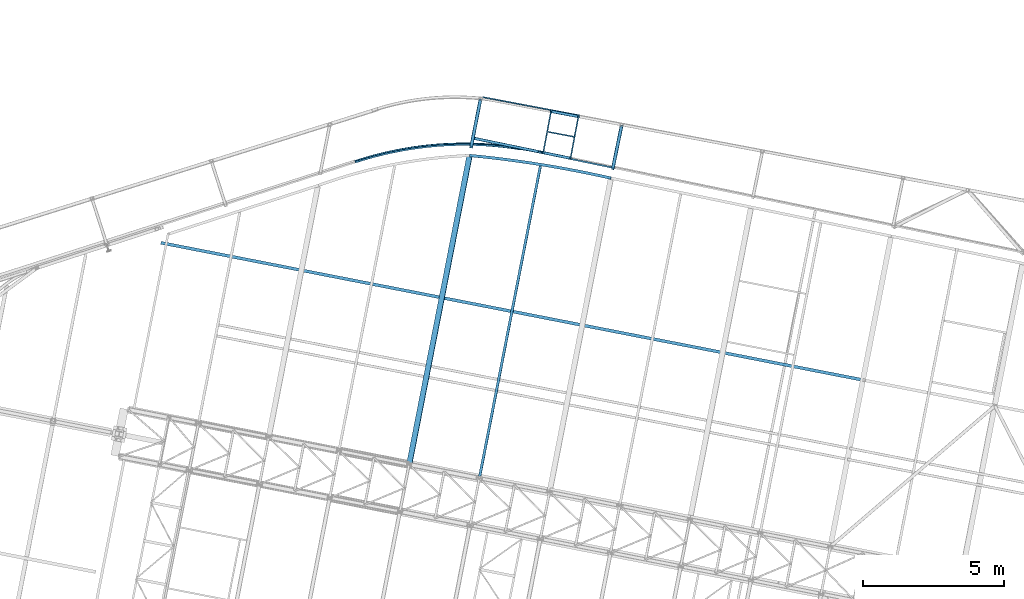
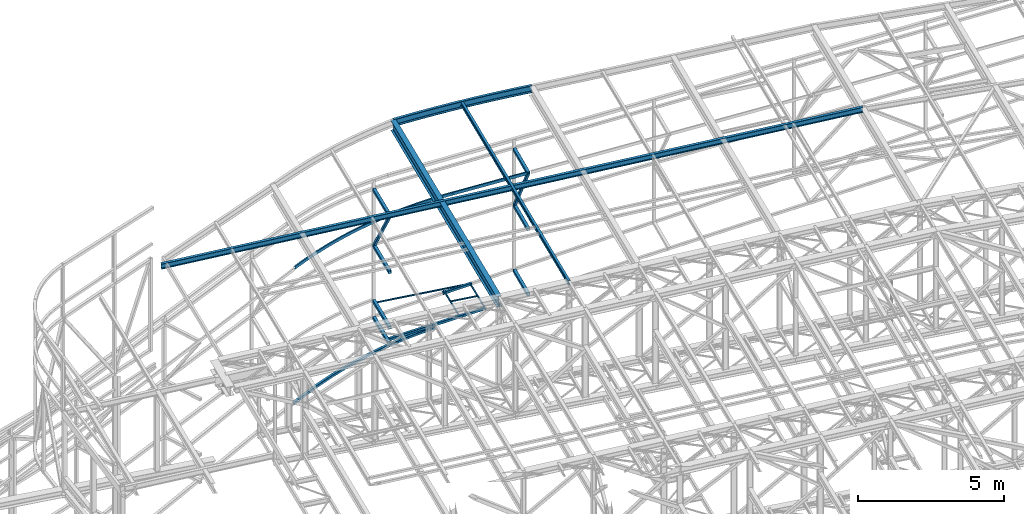
# One storey, part 87 of 215: 21 beams, 2 members, 23 elements without a shape of their own.
"""IFC2X3 building model written with IfcOpenShell, lengths in millimetres."""

from ifc_helpers import new_model, entity, si_unit, frame, origin_with_axes, origin_2d_with_axis, place, context, subcontext, project, spatial, hollow_rectangle, i_section, u_section, extrude, material, type_object, element, aggregate, save


model = new_model("IFC2X3")

# Units and contexts
model_context = context("Model", 3, precision=1e-05, world=origin_with_axes())
body_context = subcontext(model_context, "Body", "Model", "MODEL_VIEW")
ifc_project = project(units=[si_unit("LENGTHUNIT", "METRE", prefix="MILLI"), si_unit("AREAUNIT", "SQUARE_METRE"), si_unit("VOLUMEUNIT", "CUBIC_METRE"), si_unit("MASSUNIT", "GRAM", prefix="KILO"), si_unit("TIMEUNIT", "SECOND"), si_unit("PLANEANGLEUNIT", "RADIAN"), si_unit("SOLIDANGLEUNIT", "STERADIAN"), si_unit("THERMODYNAMICTEMPERATUREUNIT", "DEGREE_CELSIUS"), si_unit("LUMINOUSINTENSITYUNIT", "LUMEN")], contexts=[model_context])

# Site, building, storey
site_placement = place(None, origin_with_axes())
site = spatial("IfcSite", under=ifc_project, at=site_placement, CompositionType="ELEMENT")
building_placement = place(site_placement, origin_with_axes())
building = spatial("IfcBuilding", under=site, at=building_placement, Name="Undefined", CompositionType="ELEMENT")
storey_placement = place(building_placement, origin_with_axes())
storey = spatial("IfcBuildingStorey", under=building, at=storey_placement, Name="Undefined", CompositionType="ELEMENT", Elevation=0.0)

# Assembly, beam
assembly_1_placement = place(storey_placement, origin_with_axes())
assembly_1 = element("IfcElementAssembly", 1, at=assembly_1_placement, inside=storey, Name="Steel Assembly", AssemblyPlace="NOTDEFINED", PredefinedType="RIGID_FRAME")
ifc_material = material(Name="STEEL/S275JR")
beam_type_1 = type_object("IfcBeamType", PredefinedType="NOTDEFINED")
beam_1_placement = place(assembly_1_placement, frame((60846.3040678389, 64492.0568831528, 2809.17321889622), z_axis=(-0.981422412140383, 0.191859451027444, 0.0), x_axis=(-0.191859508000518, -0.981422401002646, -1.00000033853845e-09)))
beam_1 = element("IfcBeam", 2, at=beam_1_placement, type_object=beam_type_1, material=ifc_material, context=body_context, shape_type="SweptSolid", body=[
    extrude(hollow_rectangle(XDim=120.0, YDim=120.0, WallThickness=5.0, InnerFilletRadius=5.0, OuterFilletRadius=10.0, at=origin_2d_with_axis()), frame((1602.56698386637, -4.54747350555061e-13, -3.72828463453371e-31), z_axis=(-1.0, 0.0, 0.0), x_axis=(-6.93889390390723e-18, -1.0, -3.46944695195361e-18)), (0.0, 0.0, 1.0), 1602.6),
])
aggregate(assembly_1, [beam_1])

assembly_2_placement = place(storey_placement, origin_with_axes())
assembly_2 = element("IfcElementAssembly", 3, at=assembly_2_placement, inside=storey, Name="Steel Assembly", AssemblyPlace="NOTDEFINED", PredefinedType="RIGID_FRAME")
beam_2_placement = place(assembly_2_placement, frame((60846.3043026314, 64492.0568371658, 3509.99791160722), z_axis=(-0.981422412140383, 0.191859451027444, 0.0), x_axis=(-0.191859508000518, -0.981422401002646, -1.00000033853845e-09)))
beam_2 = element("IfcBeam", 4, at=beam_2_placement, type_object=beam_type_1, material=ifc_material, context=body_context, shape_type="SweptSolid", body=[
    extrude(hollow_rectangle(XDim=120.0, YDim=120.0, WallThickness=5.0, InnerFilletRadius=5.0, OuterFilletRadius=10.0, at=origin_2d_with_axis()), frame((1692.56697598015, -4.54747350886464e-13, -4.69781706863335e-14), z_axis=(-1.0, 0.0, 0.0), x_axis=(-6.93889390390723e-18, -1.0, -3.46944695195361e-18)), (0.0, 0.0, 1.0), 1692.6),
])
aggregate(assembly_2, [beam_2])

assembly_3_placement = place(storey_placement, origin_with_axes())
assembly_3 = element("IfcElementAssembly", 5, at=assembly_3_placement, inside=storey, Name="Steel Assembly", AssemblyPlace="NOTDEFINED", PredefinedType="RIGID_FRAME")
beam_3_placement = place(assembly_3_placement, frame((60846.3043026202, 64492.0568372251, 5833.71199781246), z_axis=(-0.981422412140383, 0.191859451027444, 0.0), x_axis=(-0.191859508000518, -0.981422401002646, -1.00000033853845e-09)))
beam_3 = element("IfcBeam", 6, at=beam_3_placement, type_object=beam_type_1, material=ifc_material, context=body_context, shape_type="SweptSolid", body=[
    extrude(hollow_rectangle(XDim=120.0, YDim=120.0, WallThickness=5.0, InnerFilletRadius=5.0, OuterFilletRadius=10.0, at=origin_2d_with_axis()), frame((1692.56697598015, -4.54747350886464e-13, -4.69781706863335e-14), z_axis=(-1.0, 0.0, 0.0), x_axis=(-6.93889390390723e-18, -1.0, -3.46944695195361e-18)), (0.0, 0.0, 1.0), 1692.6),
])
aggregate(assembly_3, [beam_3])

assembly_4_placement = place(storey_placement, origin_with_axes())
assembly_4 = element("IfcElementAssembly", 7, at=assembly_4_placement, inside=storey, Name="Steel Assembly", AssemblyPlace="NOTDEFINED", PredefinedType="RIGID_FRAME")
beam_4_placement = place(assembly_4_placement, frame((60846.3043044082, 64492.0568372218, 8175.38817858846), z_axis=(-0.981422412140383, 0.191859451027444, 0.0), x_axis=(-0.191859508000518, -0.981422401002646, -1.00000033853845e-09)))
beam_4 = element("IfcBeam", 8, at=beam_4_placement, type_object=beam_type_1, material=ifc_material, context=body_context, shape_type="SweptSolid", body=[
    extrude(hollow_rectangle(XDim=120.0, YDim=120.0, WallThickness=5.0, InnerFilletRadius=5.0, OuterFilletRadius=10.0, at=origin_2d_with_axis()), frame((1692.56697598015, -4.54747350886464e-13, -4.69781706863335e-14), z_axis=(-1.0, 0.0, 0.0), x_axis=(-6.93889390390723e-18, -1.0, -3.46944695195361e-18)), (0.0, 0.0, 1.0), 1692.6),
])
aggregate(assembly_4, [beam_4])

assembly_5_placement = place(storey_placement, origin_with_axes())
assembly_5 = element("IfcElementAssembly", 9, at=assembly_5_placement, inside=storey, Name="Steel Assembly", AssemblyPlace="NOTDEFINED", PredefinedType="RIGID_FRAME")
beam_5_placement = place(assembly_5_placement, frame((65863.2951128637, 63551.7907925705, 6332.98385608144), z_axis=(0.97957922139794, -0.201058571081677, 0.0), x_axis=(-0.201058572041247, -0.979579221200988, -1.00000033874093e-09)))
beam_5 = element("IfcBeam", 10, at=beam_5_placement, type_object=beam_type_1, material=ifc_material, context=body_context, shape_type="SweptSolid", body=[
    extrude(hollow_rectangle(XDim=120.0, YDim=120.0, WallThickness=5.0, InnerFilletRadius=5.0, OuterFilletRadius=10.0, at=origin_2d_with_axis()), frame((1518.08277362937, 9.09494701772928e-13, 4.21352612142536e-14), z_axis=(-1.0, 0.0, 0.0), x_axis=(-6.93889390390723e-18, -1.0, -3.46944695195361e-18)), (0.0, 0.0, 1.0), 1518.1),
])
aggregate(assembly_5, [beam_5])

assembly_6_placement = place(storey_placement, origin_with_axes())
assembly_6 = element("IfcElementAssembly", 11, at=assembly_6_placement, inside=storey, Name="Steel Assembly", AssemblyPlace="NOTDEFINED", PredefinedType="RIGID_FRAME")
beam_6_placement = place(assembly_6_placement, frame((65863.2951130029, 63551.7907946507, 3602.7948409245), z_axis=(0.97957922139794, -0.201058571081677, 0.0), x_axis=(-0.201058572041247, -0.979579221200988, -1.00000033874093e-09)))
beam_6 = element("IfcBeam", 12, at=beam_6_placement, type_object=beam_type_1, material=ifc_material, context=body_context, shape_type="SweptSolid", body=[
    extrude(hollow_rectangle(XDim=120.0, YDim=120.0, WallThickness=5.0, InnerFilletRadius=5.0, OuterFilletRadius=10.0, at=origin_2d_with_axis()), frame((1518.08277362937, 9.09494701772928e-13, 4.21352612142536e-14), z_axis=(-1.0, 0.0, 0.0), x_axis=(-6.93889390390723e-18, -1.0, -3.46944695195361e-18)), (0.0, 0.0, 1.0), 1518.1),
])
aggregate(assembly_6, [beam_6])

assembly_7_placement = place(storey_placement, origin_with_axes())
assembly_7 = element("IfcElementAssembly", 13, at=assembly_7_placement, inside=storey, Name="Steel Assembly", AssemblyPlace="NOTDEFINED", PredefinedType="RIGID_FRAME")
beam_7_placement = place(assembly_7_placement, frame((65863.2951129865, 63551.7907898595, 8674.00008624477), z_axis=(0.97957922139794, -0.201058571081677, 0.0), x_axis=(-0.201058572041247, -0.979579221200988, -1.00000033874093e-09)))
beam_7 = element("IfcBeam", 14, at=beam_7_placement, type_object=beam_type_1, material=ifc_material, context=body_context, shape_type="SweptSolid", body=[
    extrude(hollow_rectangle(XDim=120.0, YDim=120.0, WallThickness=5.0, InnerFilletRadius=5.0, OuterFilletRadius=10.0, at=origin_2d_with_axis()), frame((1518.08277362937, 9.09494701772928e-13, 4.21352612142536e-14), z_axis=(-1.0, 0.0, 0.0), x_axis=(-6.93889390390723e-18, -1.0, -3.46944695195361e-18)), (0.0, 0.0, 1.0), 1518.1),
])
aggregate(assembly_7, [beam_7])

assembly_8_placement = place(storey_placement, origin_with_axes())
assembly_8 = element("IfcElementAssembly", 15, at=assembly_8_placement, inside=storey, Name="Steel Assembly", AssemblyPlace="NOTDEFINED", PredefinedType="RIGID_FRAME")
beam_type_2 = type_object("IfcBeamType", PredefinedType="NOTDEFINED")
beam_8_placement = place(assembly_8_placement, frame((56400.4261079201, 62309.4328289021, 2102.02367266955), z_axis=(-0.0819909300056613, 0.996340556068799, 0.024145056001667), x_axis=(0.986497951902203, 0.077687055992299, 0.144175282985707)))
beam_8 = element("IfcBeam", 16, at=beam_8_placement, type_object=beam_type_2, material=ifc_material, Name="LISSE", context=body_context, shape_type="SweptSolid", body=[
    entity("IfcRevolvedAreaSolid", entity("IfcRectangleHollowProfileDef", "AREA", None, entity("IfcAxis2Placement2D", entity("IfcCartesianPoint", [0.0, 0.0]), entity("IfcDirection", [1.0, 0.0])), 100.0, 100.0, 5.0, 5.0, 10.0), entity("IfcAxis2Placement3D", entity("IfcCartesianPoint", [5938.35393194914, 1.64822431590581e-13, -3.86302574040425e-14]), entity("IfcDirection", [-0.971610112147189, -2.77884267791936e-17, 0.23658780605375]), entity("IfcDirection", [-6.93889390390723e-18, -1.0, -3.46944695195361e-18])), entity("IfcAxis1Placement", entity("IfcCartesianPoint", [0.0, -12550.0, 0.0]), entity("IfcDirection", [1.0, 0.0, 0.0])), 0.477704889269038),
])
aggregate(assembly_8, [beam_8])

assembly_9_placement = place(storey_placement, origin_with_axes())
assembly_9 = element("IfcElementAssembly", 17, at=assembly_9_placement, inside=storey, Name="Steel Assembly", AssemblyPlace="NOTDEFINED", PredefinedType="RIGID_FRAME")
beam_9_placement = place(assembly_9_placement, frame((63035.3702725266, 62638.7162082398, 3180.57821487935), z_axis=(0.202811574087882, 0.979217782424315, -5.19999998912453e-08), x_axis=(0.967507450041113, -0.200386169008516, 0.154190523006552)))
beam_9 = element("IfcBeam", 18, at=beam_9_placement, type_object=beam_type_2, material=ifc_material, Name="LISSE", context=body_context, shape_type="SweptSolid", body=[
    extrude(hollow_rectangle(XDim=100.0, YDim=100.0, WallThickness=5.0, InnerFilletRadius=5.0, OuterFilletRadius=10.0, at=origin_2d_with_axis()), frame((1064.70209946629, -9.09494701772928e-13, -1.45202017760121e-11), z_axis=(-1.0, 0.0, 0.0), x_axis=(-6.93889390390723e-18, -1.0, -3.46944695195361e-18)), (0.0, 0.0, 1.0), 1064.7),
])
aggregate(assembly_9, [beam_9])

assembly_10_placement = place(storey_placement, origin_with_axes())
assembly_10 = element("IfcElementAssembly", 19, at=assembly_10_placement, inside=storey, Name="Steel Assembly", AssemblyPlace="NOTDEFINED", PredefinedType="RIGID_FRAME")
beam_10_placement = place(assembly_10_placement, frame((60564.7939410119, 63150.4118311355, 2786.84537497598), z_axis=(0.202811574087882, 0.979217782424315, -5.19999998912453e-08), x_axis=(0.967507450041113, -0.200386169008516, 0.154190523006552)))
beam_10 = element("IfcBeam", 20, at=beam_10_placement, type_object=beam_type_2, material=ifc_material, Name="LISSE", context=body_context, shape_type="SweptSolid", body=[
    extrude(hollow_rectangle(XDim=100.0, YDim=100.0, WallThickness=5.0, InnerFilletRadius=5.0, OuterFilletRadius=10.0, at=origin_2d_with_axis()), frame((2553.54760472388, 9.8036988540395e-13, 6.11927324869339e-14), z_axis=(-1.0, 0.0, 0.0), x_axis=(-6.93889390390723e-18, -1.0, -3.46944695195361e-18)), (0.0, 0.0, 1.0), 2553.5),
])
aggregate(assembly_10, [beam_10])

assembly_11_placement = place(storey_placement, origin_with_axes())
assembly_11 = element("IfcElementAssembly", 21, at=assembly_11_placement, inside=storey, Name="Steel Assembly", AssemblyPlace="NOTDEFINED", PredefinedType="RIGID_FRAME")
beam_11_placement = place(assembly_11_placement, frame((63332.9613900655, 64100.4917012047, 3201.85182154818), z_axis=(0.185059002917875, 0.982727411563879, 0.0), x_axis=(0.970975106212946, -0.182845907040102, 0.154190523033816)))
beam_11 = element("IfcBeam", 22, at=beam_11_placement, type_object=beam_type_2, material=ifc_material, Name="LISSE", context=body_context, shape_type="SweptSolid", body=[
    extrude(hollow_rectangle(XDim=100.0, YDim=100.0, WallThickness=5.0, InnerFilletRadius=5.0, OuterFilletRadius=10.0, at=origin_2d_with_axis()), frame((1064.70209946629, -9.09494701772928e-13, -1.45202017760121e-11), z_axis=(-1.0, 0.0, 0.0), x_axis=(-6.93889390390723e-18, -1.0, -3.46944695195361e-18)), (0.0, 0.0, 1.0), 1064.7),
])
aggregate(assembly_11, [beam_11])

assembly_12_placement = place(storey_placement, origin_with_axes())
assembly_12 = element("IfcElementAssembly", 23, at=assembly_12_placement, inside=storey, Name="Steel Assembly", AssemblyPlace="NOTDEFINED", PredefinedType="RIGID_FRAME")
beam_type_3 = type_object("IfcBeamType", PredefinedType="NOTDEFINED")
beam_12_placement = place(assembly_12_placement, frame((63200.6196642151, 63377.4039981066, 3334.99966279131), z_axis=(0.0, 0.0, 1.0), x_axis=(0.982583013200276, -0.185824170037877, 0.0)))
beam_12 = element("IfcBeam", 24, at=beam_12_placement, type_object=beam_type_3, material=ifc_material, context=body_context, shape_type="SweptSolid", body=[
    extrude(hollow_rectangle(XDim=50.0, YDim=50.0, WallThickness=3.0, InnerFilletRadius=3.0, OuterFilletRadius=6.0, at=origin_2d_with_axis()), frame((1040.00001665534, 0.0, 4.54747350886464e-13), z_axis=(-1.0, 0.0, 0.0), x_axis=(-6.93889390390723e-18, -1.0, -3.46944695195361e-18)), (0.0, 0.0, 1.0), 1040.0),
])
aggregate(assembly_12, [beam_12])

assembly_13_placement = place(storey_placement, origin_with_axes())
assembly_13 = element("IfcElementAssembly", 25, at=assembly_13_placement, inside=storey, Name="Steel Assembly", AssemblyPlace="NOTDEFINED", PredefinedType="RIGID_FRAME")
beam_13_placement = place(assembly_13_placement, frame((60929.1456341112, 64603.2398358579, 3334.9996627777), z_axis=(0.0, 0.0, 1.0), x_axis=(0.982565923617697, -0.185914511927664, 0.0)))
beam_13 = element("IfcBeam", 26, at=beam_13_placement, type_object=beam_type_3, material=ifc_material, context=body_context, shape_type="SweptSolid", body=[
    extrude(hollow_rectangle(XDim=50.0, YDim=50.0, WallThickness=3.0, InnerFilletRadius=3.0, OuterFilletRadius=6.0, at=origin_2d_with_axis()), frame((3499.26420533172, 0.0, 0.0), z_axis=(-1.0, 0.0, 0.0), x_axis=(-6.93889390390723e-18, -1.0, -3.46944695195361e-18)), (0.0, 0.0, 1.0), 3499.3),
])
aggregate(assembly_13, [beam_13])

assembly_14_placement = place(storey_placement, origin_with_axes())
assembly_14 = element("IfcElementAssembly", 27, at=assembly_14_placement, inside=storey, Name="Steel Assembly", AssemblyPlace="NOTDEFINED", PredefinedType="RIGID_FRAME")
beam_14_placement = place(assembly_14_placement, frame((64045.0524665882, 62377.9663630105, 3334.99966285638), z_axis=(0.0, 0.0, -1.0), x_axis=(0.185294237017553, 0.982683085093095, 0.0)))
beam_14 = element("IfcBeam", 28, at=beam_14_placement, type_object=beam_type_3, material=ifc_material, context=body_context, shape_type="SweptSolid", body=[
    extrude(hollow_rectangle(XDim=50.0, YDim=50.0, WallThickness=3.0, InnerFilletRadius=3.0, OuterFilletRadius=6.0, at=origin_2d_with_axis()), frame((1632.17012996255, 0.0, 0.0), z_axis=(-1.0, 0.0, 0.0), x_axis=(-6.93889390390723e-18, -1.0, -3.46944695195361e-18)), (0.0, 0.0, 1.0), 1632.2),
])
aggregate(assembly_14, [beam_14])

assembly_15_placement = place(storey_placement, origin_with_axes())
assembly_15 = element("IfcElementAssembly", 29, at=assembly_15_placement, inside=storey, Name="Steel Assembly", AssemblyPlace="NOTDEFINED", PredefinedType="RIGID_FRAME")
beam_15_placement = place(assembly_15_placement, frame((63075.6414931099, 62579.6785148873, 3334.99966267219), z_axis=(0.0, 0.0, 1.0), x_axis=(0.185294237017553, 0.982683085093095, 0.0)))
beam_15 = element("IfcBeam", 30, at=beam_15_placement, type_object=beam_type_3, material=ifc_material, context=body_context, shape_type="SweptSolid", body=[
    extrude(hollow_rectangle(XDim=50.0, YDim=50.0, WallThickness=3.0, InnerFilletRadius=3.0, OuterFilletRadius=6.0, at=origin_2d_with_axis()), frame((1614.13814754926, 0.0, 0.0), z_axis=(-1.0, 0.0, 0.0), x_axis=(-6.93889390390723e-18, -1.0, -3.46944695195361e-18)), (0.0, 0.0, 1.0), 1614.1),
])
aggregate(assembly_15, [beam_15])

assembly_16_placement = place(storey_placement, origin_with_axes())
assembly_16 = element("IfcElementAssembly", 31, at=assembly_16_placement, inside=storey, Name="Steel Assembly", AssemblyPlace="NOTDEFINED", PredefinedType="RIGID_FRAME")
beam_type_4 = type_object("IfcBeamType", Name="IPE180", PredefinedType="NOTDEFINED")
beam_16_placement = place(assembly_16_placement, frame((60813.588311652, 51052.3122572833, 12435.6309830991), z_axis=(-0.0304080349967745, 0.00594450299936818, 0.999519891893966), x_axis=(0.191845211931802, 0.981425195651121, 9.9999994476379e-10)))
beam_16 = element("IfcBeam", 32, at=beam_16_placement, type_object=beam_type_4, material=ifc_material, ObjectType="IPE180", context=body_context, shape_type="SweptSolid", body=[
    extrude(i_section(OverallWidth=91.0, OverallDepth=180.0, WebThickness=5.300000191, FlangeThickness=8.0, FilletRadius=9.0, at=origin_2d_with_axis()), frame((11368.1805399916, -7.29749999652721e-12, 1.69898432619937e-17), z_axis=(-1.0, 0.0, 0.0), x_axis=(-6.93889390390723e-18, -1.0, -3.46944695195361e-18)), (0.0, 0.0, 1.0), 11368.2),
])
aggregate(assembly_16, [beam_16])

# Assembly, member
assembly_17_placement = place(storey_placement, origin_with_axes())
assembly_17 = element("IfcElementAssembly", 33, at=assembly_17_placement, inside=storey, Name="Steel Assembly", AssemblyPlace="NOTDEFINED", PredefinedType="RIGID_FRAME")
member_type = type_object("IfcMemberType", PredefinedType="NOTDEFINED")
member_1_placement = place(assembly_17_placement, frame((60521.5693642332, 62830.9337504331, 8195.38817689351), z_axis=(-0.981422153904125, 0.191860771981257, 9.71999999724718e-07), x_axis=(0.111763166992201, 0.571704353960101, -0.812811863943273)))
member_1 = element("IfcMember", 34, at=member_1_placement, type_object=member_type, material=ifc_material, context=body_context, shape_type="SweptSolid", body=[
    extrude(hollow_rectangle(XDim=100.0, YDim=100.0, WallThickness=5.0, InnerFilletRadius=5.0, OuterFilletRadius=10.0, at=origin_2d_with_axis()), frame((2905.56312381349, -7.27595761418343e-12, 7.23360164309341e-12), z_axis=(-1.0, 0.0, 0.0), x_axis=(-6.93889390390723e-18, -1.0, -3.46944695195361e-18)), (0.0, 0.0, 1.0), 2905.6),
])
aggregate(assembly_17, [member_1])

assembly_18_placement = place(storey_placement, origin_with_axes())
assembly_18 = element("IfcElementAssembly", 35, at=assembly_18_placement, inside=storey, Name="Steel Assembly", AssemblyPlace="NOTDEFINED", PredefinedType="RIGID_FRAME")
member_2_placement = place(assembly_18_placement, frame((65558.0715610706, 62064.7084519168, 8694.00008624257), z_axis=(-0.979643449972024, 0.200745282994263, -0.000205626999993495), x_axis=(0.108738474987036, 0.529785675936839, -0.841132023899721)))
member_2 = element("IfcMember", 36, at=member_2_placement, type_object=member_type, material=ifc_material, context=body_context, shape_type="SweptSolid", body=[
    extrude(hollow_rectangle(XDim=100.0, YDim=100.0, WallThickness=5.0, InnerFilletRadius=5.0, OuterFilletRadius=10.0, at=origin_2d_with_axis()), frame((2806.95082610707, 1.48635493719803e-11, -7.29155453787502e-12), z_axis=(-1.0, 0.0, 0.0), x_axis=(-6.93889390390723e-18, -1.0, -3.46944695195361e-18)), (0.0, 0.0, 1.0), 2807.0),
])
aggregate(assembly_18, [member_2])

# Assembly, beam
assembly_19_placement = place(storey_placement, origin_with_axes())
assembly_19 = element("IfcElementAssembly", 37, at=assembly_19_placement, inside=storey, Name="Steel Assembly", AssemblyPlace="NOTDEFINED", PredefinedType="RIGID_FRAME")
beam_type_5 = type_object("IfcBeamType", Name="UPN120", PredefinedType="NOTDEFINED")
beam_17_placement = place(assembly_19_placement, frame((62900.7320374596, 62643.4299704408, 8411.28197668016), z_axis=(0.095420952961244, -0.0197564639919738, -0.995240937595767), x_axis=(0.974571277768616, -0.201780445952093, 0.0974447339768643)))
beam_17 = element("IfcBeam", 38, at=beam_17_placement, type_object=beam_type_5, material=ifc_material, ObjectType="UPN120", context=body_context, shape_type="SweptSolid", body=[
    extrude(u_section(Depth=120.0, FlangeWidth=55.0, WebThickness=7.0, FlangeThickness=9.0, FilletRadius=9.0, EdgeRadius=4.5, FlangeSlope=0.0798299857122373, at=origin_2d_with_axis()), frame((2694.75998714672, -4.30714237094463e-14, 0.0), z_axis=(-1.0, 0.0, 0.0), x_axis=(-6.93889390390723e-18, -1.0, -3.46944695195361e-18)), (0.0, 0.0, 1.0), 2694.8),
])
aggregate(assembly_19, [beam_17])

assembly_20_placement = place(storey_placement, origin_with_axes())
assembly_20 = element("IfcElementAssembly", 39, at=assembly_20_placement, inside=storey, Name="Steel Assembly", AssemblyPlace="NOTDEFINED", PredefinedType="RIGID_FRAME")
beam_18_placement = place(assembly_20_placement, frame((56422.5117245471, 62290.824246937, 7776.72600908181), z_axis=(0.0972994639544981, 0.00531888799751406, -0.995240937534544), x_axis=(0.99375723459007, 0.054323866977591, 0.0974447339598035)))
beam_18 = element("IfcBeam", 40, at=beam_18_placement, type_object=beam_type_5, material=ifc_material, ObjectType="UPN120", context=body_context, shape_type="SweptSolid", body=[
    entity("IfcRevolvedAreaSolid", entity("IfcUShapeProfileDef", "AREA", None, entity("IfcAxis2Placement2D", entity("IfcCartesianPoint", [0.0, 0.0]), entity("IfcDirection", [1.0, 0.0])), 120.0, 55.0, 7.0, 9.0, 9.0, 4.5, 0.0798299857122373), entity("IfcAxis2Placement3D", entity("IfcCartesianPoint", [6518.94527567778, -7.26697174659769e-12, 0.0]), entity("IfcDirection", [-0.967177851459293, -0.254100381043765, 7.84883370534091e-20]), entity("IfcDirection", [0.254100381043765, -0.967177851459293, 2.98748789293843e-19])), entity("IfcAxis1Placement", entity("IfcCartesianPoint", [-12827.5, 0.0, 0.0]), entity("IfcDirection", [-6.93889390390723e-18, -1.0, -3.46944695195361e-18])), 0.513834881936001),
])
aggregate(assembly_20, [beam_18])

assembly_21_placement = place(storey_placement, origin_with_axes())
assembly_21 = element("IfcElementAssembly", 41, at=assembly_21_placement, inside=storey, Name="Steel Assembly", AssemblyPlace="NOTDEFINED", PredefinedType="RIGID_FRAME")
beam_type_6 = type_object("IfcBeamType", Name="IPE220", PredefinedType="NOTDEFINED")
beam_19_placement = place(assembly_21_placement, frame((49492.4776062093, 59423.737431231, 12021.4206180587), z_axis=(-0.0304080349967745, 0.00594450299936818, 0.999519891893966), x_axis=(0.980951223231219, -0.191767338045201, 0.0309836360073031)))
beam_19 = element("IfcBeam", 42, at=beam_19_placement, type_object=beam_type_6, material=ifc_material, Name="POUTRE", ObjectType="IPE220", context=body_context, shape_type="SweptSolid", body=[
    extrude(i_section(OverallWidth=110.0, OverallDepth=220.0, WebThickness=5.900000095, FlangeThickness=9.199999809, FilletRadius=12.0, at=origin_2d_with_axis()), frame((25446.9780052021, -9.40605849855046e-13, -1.81898940354586e-12), z_axis=(-1.0, 0.0, 0.0), x_axis=(-6.93889390390723e-18, -1.0, -3.46944695195361e-18)), (0.0, 0.0, 1.0), 25447.0),
])
aggregate(assembly_21, [beam_19])

assembly_22_placement = place(storey_placement, origin_with_axes())
assembly_22 = element("IfcElementAssembly", 43, at=assembly_22_placement, inside=storey, Name="Steel Assembly", AssemblyPlace="NOTDEFINED", PredefinedType="RIGID_FRAME")
beam_type_7 = type_object("IfcBeamType", Name="UPE300", PredefinedType="NOTDEFINED")
beam_20_placement = place(assembly_22_placement, frame((60472.0165274936, 62527.9836903778, 12297.0310419275), z_axis=(-0.0305338490035784, 0.00490439200057158, 0.999521701117155), x_axis=(0.986872478425268, -0.158512909068307, 0.0309252160133266)))
beam_20 = element("IfcBeam", 44, at=beam_20_placement, type_object=beam_type_7, material=ifc_material, Name="POUTRE", ObjectType="UPE300", context=body_context, shape_type="SweptSolid", body=[
    entity("IfcRevolvedAreaSolid", entity("IfcUShapeProfileDef", "AREA", None, entity("IfcAxis2Placement2D", entity("IfcCartesianPoint", [0.0, 0.0]), entity("IfcDirection", [1.0, 0.0])), 300.0, 100.0, 9.5, 15.0, 15.0), entity("IfcAxis2Placement3D", entity("IfcCartesianPoint", [5085.93802930141, -1.44585932369124e-11, 1.76453921935848e-14]), entity("IfcDirection", [-0.997972041034588, 0.0636537926070265, -3.40975998545135e-18]), entity("IfcDirection", [-0.0636537926070264, -0.997972041034588, -1.04631345764166e-18])), entity("IfcAxis1Placement", entity("IfcCartesianPoint", [39950.0, 0.0, 0.0]), entity("IfcDirection", [0.0, 1.0, 0.0])), 0.127393713270033),
])
aggregate(assembly_22, [beam_20])

assembly_23_placement = place(storey_placement, origin_with_axes())
assembly_23 = element("IfcElementAssembly", 45, at=assembly_23_placement, inside=storey, Name="Steel Assembly", AssemblyPlace="NOTDEFINED", PredefinedType="RIGID_FRAME")
beam_type_8 = type_object("IfcBeamType", Name="IPE450", PredefinedType="NOTDEFINED")
beam_21_placement = place(assembly_23_placement, frame((58321.4676828517, 51539.4997345581, 12219.7593585603), z_axis=(-0.0304080349967745, 0.00594450299936818, 0.999519891893966), x_axis=(0.191845211931802, 0.981425195651121, 9.9999994476379e-10)))
beam_21 = element("IfcBeam", 46, at=beam_21_placement, type_object=beam_type_8, material=ifc_material, Name="POUTRE", ObjectType="IPE450", context=body_context, shape_type="SweptSolid", body=[
    extrude(i_section(OverallWidth=190.0, OverallDepth=450.0, WebThickness=9.399999619, FlangeThickness=14.60000038, FilletRadius=21.0, at=origin_2d_with_axis()), frame((11196.7908439877, 6.96518423926074e-12, -1.82870107151219e-12), z_axis=(-1.0, 0.0, 0.0), x_axis=(-6.93889390390723e-18, -1.0, -3.46944695195361e-18)), (0.0, 0.0, 1.0), 11196.8),
])
aggregate(assembly_23, [beam_21])

save(model, "model.ifc")
